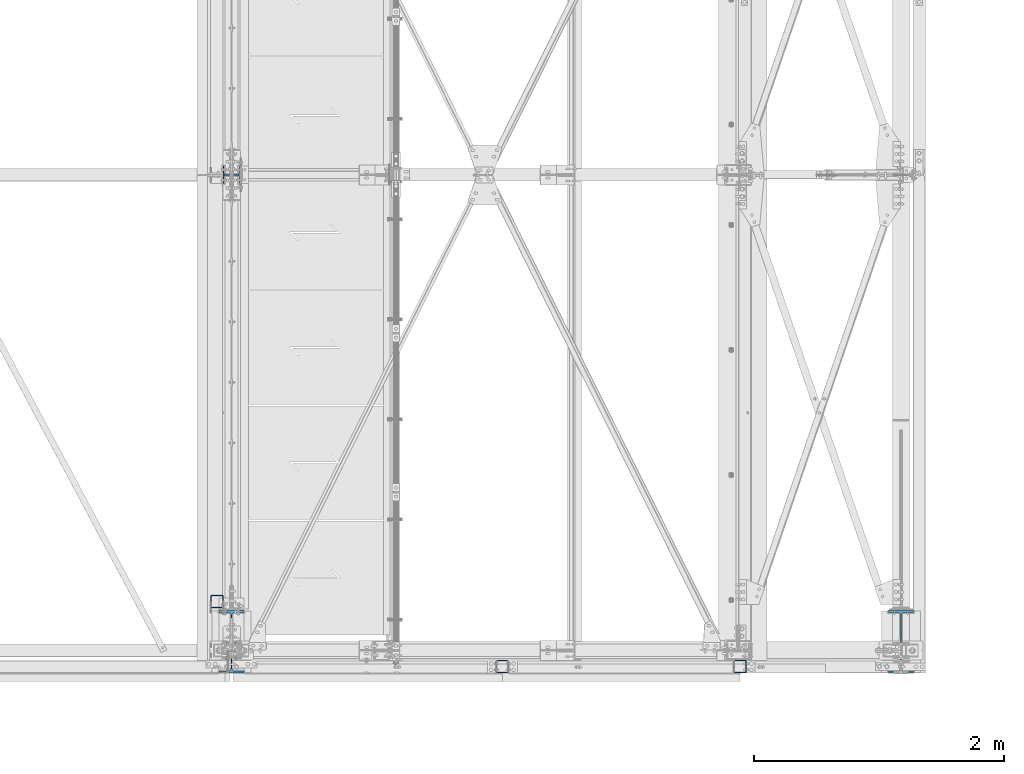
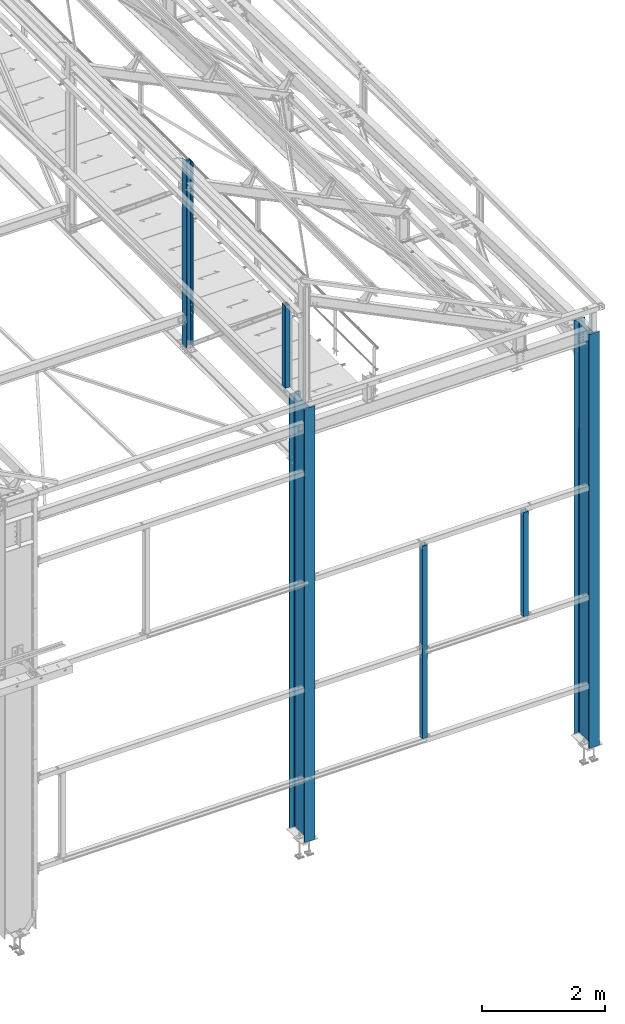
# One storey, part 16 of 496: 6 columns, 6 elements without a shape of their own.
"""IFC2X3 building model written with IfcOpenShell, lengths in millimetres."""

from ifc_helpers import new_model, si_unit, frame, origin_with_axes, origin_2d_with_axis, place, context, subcontext, project, spatial, hollow_rectangle, i_section, extrude, clip, halfspace, material, type_object, element, aggregate, save


model = new_model("IFC2X3")

# Units and contexts
model_context = context("Model", 3, precision=1e-05, world=origin_with_axes())
body_context = subcontext(model_context, "Body", "Model", "MODEL_VIEW")
ifc_project = project(units=[si_unit("LENGTHUNIT", "METRE", prefix="MILLI"), si_unit("AREAUNIT", "SQUARE_METRE"), si_unit("VOLUMEUNIT", "CUBIC_METRE"), si_unit("MASSUNIT", "GRAM", prefix="KILO"), si_unit("TIMEUNIT", "SECOND"), si_unit("PLANEANGLEUNIT", "RADIAN"), si_unit("SOLIDANGLEUNIT", "STERADIAN"), si_unit("THERMODYNAMICTEMPERATUREUNIT", "DEGREE_CELSIUS"), si_unit("LUMINOUSINTENSITYUNIT", "LUMEN")], contexts=[model_context])

# Site, building, storey
site_placement = place(None, origin_with_axes())
site = spatial("IfcSite", under=ifc_project, at=site_placement, CompositionType="ELEMENT")
building_placement = place(site_placement, origin_with_axes())
building = spatial("IfcBuilding", under=site, at=building_placement, Name="Undefined", CompositionType="ELEMENT")
storey_placement = place(building_placement, origin_with_axes())
storey = spatial("IfcBuildingStorey", under=building, at=storey_placement, Name="Undefined", CompositionType="ELEMENT", Elevation=0.0)

# Assembly, column
assembly_1_placement = place(storey_placement, origin_with_axes())
assembly_1 = element("IfcElementAssembly", 1, at=assembly_1_placement, inside=storey, Name="MONTANT", AssemblyPlace="NOTDEFINED", PredefinedType="NOTDEFINED")
ifc_material_1 = material(Name="Undefined/S235-E24")
column_type_1 = type_object("IfcColumnType", PredefinedType="NOTDEFINED")
column_1_placement = place(assembly_1_placement, frame((34163.5001162734, 390.000158152008, 8555.00000000001), z_axis=(0.0, 0.0, 1.0), x_axis=(0.0, -1.0, 0.0)))
column_1 = element("IfcColumn", 2, at=column_1_placement, type_object=column_type_1, material=ifc_material_1, Name="MONTANT", context=body_context, shape_type="SweptSolid", body=[
    extrude(hollow_rectangle(XDim=100.0, YDim=100.0, WallThickness=4.0, InnerFilletRadius=4.0, OuterFilletRadius=8.0, at=origin_2d_with_axis()), frame((0.0, 0.0, 1635.0), z_axis=(0.0, 0.0, -1.0), x_axis=(0.0, 1.0, 0.0)), (0.0, 0.0, 1.0), 1635.0),
])
aggregate(assembly_1, [column_1])

assembly_2_placement = place(storey_placement, origin_with_axes())
assembly_2 = element("IfcElementAssembly", 3, at=assembly_2_placement, inside=storey, Name="MONTANT", AssemblyPlace="NOTDEFINED", PredefinedType="NOTDEFINED")
column_2_placement = place(assembly_2_placement, frame((38345.0025836492, -129.99971712703, 2865.00000002487), z_axis=(0.0, 0.0, 1.0), x_axis=(0.0, 1.0, 0.0)))
column_2 = element("IfcColumn", 4, at=column_2_placement, type_object=column_type_1, material=ifc_material_1, Name="MONTANT", context=body_context, shape_type="SweptSolid", body=[
    extrude(hollow_rectangle(XDim=100.0, YDim=100.0, WallThickness=4.0, InnerFilletRadius=4.0, OuterFilletRadius=8.0, at=origin_2d_with_axis()), frame((0.0, 0.0, 2070.0), z_axis=(0.0, 0.0, -1.0), x_axis=(0.0, 1.0, 0.0)), (0.0, 0.0, 1.0), 2070.0),
])
aggregate(assembly_2, [column_2])

assembly_3_placement = place(storey_placement, origin_with_axes())
assembly_3 = element("IfcElementAssembly", 5, at=assembly_3_placement, inside=storey, Name="MONTANT", AssemblyPlace="NOTDEFINED", PredefinedType="NOTDEFINED")
column_3_placement = place(assembly_3_placement, frame((36445.0025831691, -129.999731123905, 1104.9999999835), z_axis=(0.0, 0.0, 1.0), x_axis=(0.0, 1.0, 0.0)))
column_3 = element("IfcColumn", 6, at=column_3_placement, type_object=column_type_1, material=ifc_material_1, Name="MONTANT", context=body_context, shape_type="SweptSolid", body=[
    extrude(hollow_rectangle(XDim=100.0, YDim=100.0, WallThickness=4.0, InnerFilletRadius=4.0, OuterFilletRadius=8.0, at=origin_2d_with_axis()), frame((0.0, 0.0, 3830.0), z_axis=(0.0, 0.0, -1.0), x_axis=(0.0, 1.0, 0.0)), (0.0, 0.0, 1.0), 3830.0),
])
aggregate(assembly_3, [column_3])

assembly_4_placement = place(storey_placement, origin_with_axes())
assembly_4 = element("IfcElementAssembly", 7, at=assembly_4_placement, inside=storey, Name="MONTANT", AssemblyPlace="NOTDEFINED", PredefinedType="NOTDEFINED")
ifc_material_2 = material(Name="Undefined/S275-E28")
column_type_2 = type_object("IfcColumnType", Name="HEA140", PredefinedType="NOTDEFINED")
column_4_placement = place(assembly_4_placement, frame((34280.0, 3800.0, 7260.0), z_axis=(0.0, 0.0, 1.0), x_axis=(-1.0, 0.0, 0.0)))
column_4 = element("IfcColumn", 8, at=column_4_placement, type_object=column_type_2, material=ifc_material_2, Name="MONTANT", ObjectType="HEA140", context=body_context, shape_type="Clipping", body=[
    clip(extrude(i_section(OverallWidth=140.0, OverallDepth=133.0, WebThickness=5.5, FlangeThickness=8.5, FilletRadius=12.0, at=origin_2d_with_axis()), frame((0.0, 0.0, 3730.84210522584), z_axis=(0.0, 0.0, -1.0), x_axis=(0.0, 1.0, 0.0)), (0.0, 0.0, 1.0), 3730.84), halfspace(frame((-66.5, 70.0, 3654.3071165161), z_axis=(-0.441220937981244, -6.28179308850765e-09, 0.89739850896185), x_axis=(0.89739850896185, 0.0, 0.441220937981244)), False)),
])
aggregate(assembly_4, [column_4])

assembly_5_placement = place(storey_placement, origin_with_axes())
assembly_5 = element("IfcElementAssembly", 9, at=assembly_5_placement, inside=storey, Name="POTEAU", AssemblyPlace="NOTDEFINED", PredefinedType="NOTDEFINED")
column_type_3 = type_object("IfcColumnType", Name="IPE500", PredefinedType="NOTDEFINED")
column_5_placement = place(assembly_5_placement, frame((39629.9971504447, 70.0, -185.0), z_axis=(0.0, 0.0, 1.0), x_axis=(0.0, 1.0, 0.0)))
column_5 = element("IfcColumn", 10, at=column_5_placement, type_object=column_type_3, material=ifc_material_2, Name="POTEAU", ObjectType="IPE500", context=body_context, shape_type="Clipping", body=[
    clip(extrude(i_section(OverallWidth=200.0, OverallDepth=500.0, WebThickness=10.19999981, FlangeThickness=16.0, FilletRadius=21.0, at=origin_2d_with_axis()), frame((0.0, -4.35957270039977e-19, 8235.00000000055), z_axis=(0.0, 0.0, -1.0), x_axis=(0.0, 1.0, 0.0)), (0.0, 0.0, 1.0), 8235.0), halfspace(frame((-250.0, 99.9999982502231, 8230.65175644266), z_axis=(0.0314107590115582, 0.0, 0.999506560367824), x_axis=(0.999506560367824, 0.0, -0.0314107590115582)), False)),
])
aggregate(assembly_5, [column_5])

assembly_6_placement = place(storey_placement, origin_with_axes())
assembly_6 = element("IfcElementAssembly", 11, at=assembly_6_placement, inside=storey, Name="POTEAU", AssemblyPlace="NOTDEFINED", PredefinedType="NOTDEFINED")
column_6_placement = place(assembly_6_placement, frame((34279.9971504447, 70.0, -185.0), z_axis=(0.0, 0.0, 1.0), x_axis=(0.0, 1.0, 0.0)))
column_6 = element("IfcColumn", 12, at=column_6_placement, type_object=column_type_3, material=ifc_material_2, Name="POTEAU", ObjectType="IPE500", context=body_context, shape_type="SweptSolid", body=[
    extrude(i_section(OverallWidth=200.0, OverallDepth=500.0, WebThickness=10.19999981, FlangeThickness=16.0, FilletRadius=21.0, at=origin_2d_with_axis()), frame((0.0, 0.0, 8625.00000000043), z_axis=(0.0, 0.0, -1.0), x_axis=(0.0, 1.0, 0.0)), (0.0, 0.0, 1.0), 8625.0),
])
aggregate(assembly_6, [column_6])

save(model, "model.ifc")
